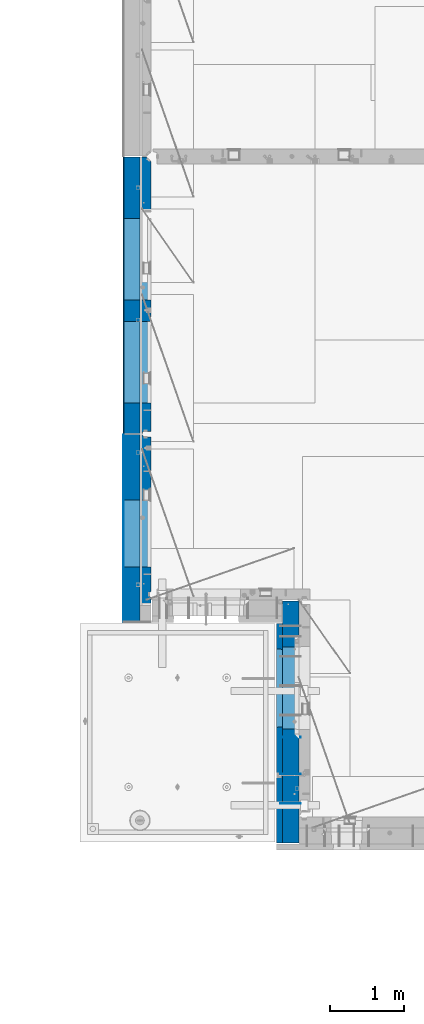
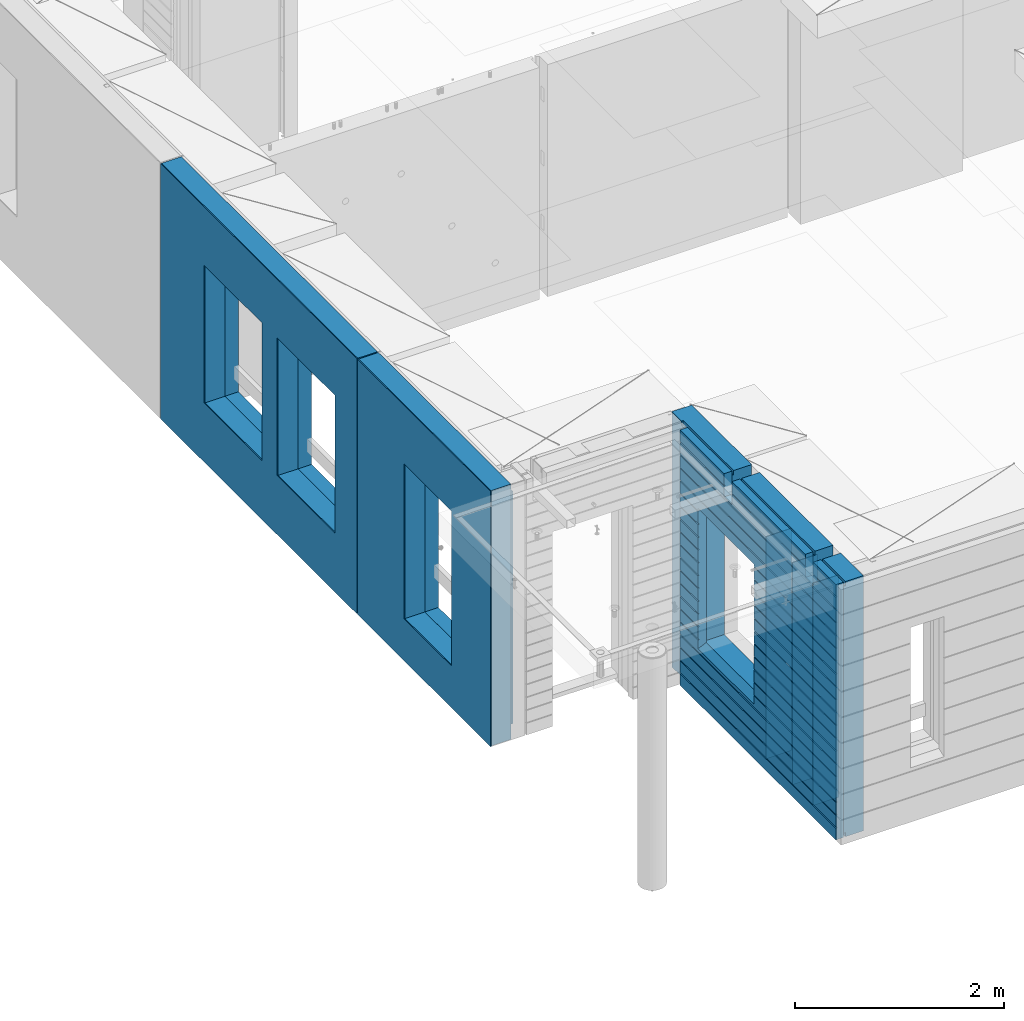
# One storey, part 219 of 341: 11 walls, 3 elements without a shape of their own.
"""IFC2X3 building model written with IfcOpenShell, lengths in millimetres."""

from ifc_helpers import new_model, si_unit, frame, origin_with_axes, place, context, subcontext, project, spatial, faceted_brep, material, type_object, element, aggregate, save


model = new_model("IFC2X3")

# Units and contexts
model_context = context("Model", 3, precision=1e-05, world=origin_with_axes())
body_context = subcontext(model_context, "Body", "Model", "MODEL_VIEW")
ifc_project = project(units=[si_unit("LENGTHUNIT", "METRE", prefix="MILLI"), si_unit("AREAUNIT", "SQUARE_METRE"), si_unit("VOLUMEUNIT", "CUBIC_METRE"), si_unit("MASSUNIT", "GRAM", prefix="KILO"), si_unit("TIMEUNIT", "SECOND"), si_unit("PLANEANGLEUNIT", "RADIAN"), si_unit("SOLIDANGLEUNIT", "STERADIAN"), si_unit("THERMODYNAMICTEMPERATUREUNIT", "DEGREE_CELSIUS"), si_unit("LUMINOUSINTENSITYUNIT", "LUMEN")], contexts=[model_context])

# Site, building, storey
site_placement = place(None, origin_with_axes())
site = spatial("IfcSite", under=ifc_project, at=site_placement, CompositionType="ELEMENT")
building_placement = place(site_placement, origin_with_axes())
building = spatial("IfcBuilding", under=site, at=building_placement, CompositionType="ELEMENT")
storey_placement = place(building_placement, origin_with_axes())
storey = spatial("IfcBuildingStorey", under=building, at=storey_placement, Name="5", CompositionType="ELEMENT", Elevation=0.0)

# Assembly, walls
assembly_1_placement = place(storey_placement, origin_with_axes())
assembly_1 = element("IfcElementAssembly", 1, at=assembly_1_placement, inside=storey, AssemblyPlace="NOTDEFINED", PredefinedType="REINFORCEMENT_UNIT")
ifc_material_1 = material(Name="Undefined")
wall_type_1 = type_object("IfcWallType", PredefinedType="NOTDEFINED")
wall_1_placement = place(assembly_1_placement, frame((10040.0, 8580.0, 95115.0), z_axis=(0.0, 0.0, 1.0), x_axis=(-1.0, 3.00000001838171e-08, 0.0)))
wall_1 = element("IfcWall", 2, at=wall_1_placement, type_object=wall_type_1, material=ifc_material_1, Name="(PD)", context=body_context, shape_type="Brep", body=[
    faceted_brep([(0.0, 5.0, -1300.0), (0.0, 5.0, 1300.0), (280.0, 5.0, 1300.0), (280.0, 5.0, -1300.0), (0.0, -5.0, 1300.0), (280.0, -5.0, 1300.0), (0.0, -5.0, -1300.0), (280.0, -5.0, -1300.0)], [[[0, 1, 2, 3]], [[1, 4, 5, 2]], [[4, 6, 7, 5]], [[6, 0, 3, 7]], [[5, 7, 3, 2]], [[6, 4, 1, 0]]]),
])
wall_2_placement = place(assembly_1_placement, frame((10040.0, 8180.0, 95115.0), z_axis=(0.0, 0.0, 1.0), x_axis=(-1.0, 3.00000001838171e-08, 0.0)))
wall_2 = element("IfcWall", 3, at=wall_2_placement, type_object=wall_type_1, material=ifc_material_1, Name="(PD)", context=body_context, shape_type="Brep", body=[
    faceted_brep([(0.0, 5.0, -1300.0), (0.0, 5.0, 1300.0), (280.0, 5.0, 1300.0), (280.0, 5.0, -1300.0), (0.0, -5.0, 1300.0), (280.0, -5.0, 1300.0), (0.0, -5.0, -1300.0), (280.0, -5.0, -1300.0)], [[[0, 1, 2, 3]], [[1, 4, 5, 2]], [[4, 6, 7, 5]], [[6, 0, 3, 7]], [[5, 7, 3, 2]], [[6, 4, 1, 0]]]),
])
wall_3_placement = place(assembly_1_placement, frame((10040.0, 9080.0, 95115.0), z_axis=(0.0, 0.0, 1.0), x_axis=(-1.0, 3.00000001838171e-08, 0.0)))
wall_3 = element("IfcWall", 4, at=wall_3_placement, type_object=wall_type_1, material=ifc_material_1, Name="(PD)", context=body_context, shape_type="Brep", body=[
    faceted_brep([(0.0, 5.0, -1300.0), (0.0, 5.0, 1300.0), (280.0, 5.0, 1300.0), (280.0, 5.0, -1300.0), (0.0, -5.0, 1300.0), (280.0, -5.0, 1300.0), (0.0, -5.0, -1300.0), (280.0, -5.0, -1300.0)], [[[0, 1, 2, 3]], [[1, 4, 5, 2]], [[4, 6, 7, 5]], [[6, 0, 3, 7]], [[5, 7, 3, 2]], [[6, 4, 1, 0]]]),
])
ifc_material_2 = material(Name="COS5gt")
wall_type_2 = type_object("IfcWallType", PredefinedType="NOTDEFINED")
wall_4_placement = place(assembly_1_placement, frame((9900.0, 8000.0, 95247.5), z_axis=(0.0, 0.0, 1.0), x_axis=(0.0, 1.0, 0.0)))
wall_4 = element("IfcWall", 5, at=wall_4_placement, type_object=wall_type_2, material=ifc_material_2, context=body_context, shape_type="Brep", body=[
    faceted_brep([(-355.0, 110.0, -1442.5), (2751.0, 110.0, -1442.5), (2751.0, 90.0, -1442.5), (-355.0, 90.0, -1442.5), (2935.0, 110.0, -1492.5), (2935.0, -110.0, -1492.5), (-355.0, -110.0, -1492.5), (-355.0, 90.0, -1492.5), (2751.0, 90.0, -1492.5), (2751.0, 110.0, -1492.5), (2935.0, -110.0, 1492.5), (2935.0, 110.0, 1492.5), (2751.0, 110.0, 1492.5), (2751.0, 90.0, 1492.5), (1785.0, 90.0, 1492.5), (1785.0, -110.0, 1492.5), (2751.0, 90.0, 1442.5), (1785.0, 90.0, 1442.5), (2751.0, 110.0, 1442.5), (1785.0, 110.0, 1442.5), (1785.0, 110.0, 1222.5), (1785.0, -110.0, 1222.5), (1635.0, 110.0, 1222.5), (1635.0, -110.0, 1222.5), (1635.0, -110.0, 1492.5), (1635.0, 90.0, 1492.5), (229.999999999998, 90.0, 1492.5), (229.999999999998, -110.0, 1492.5), (1635.0, 90.0, 1442.5), (229.999999999998, 90.0, 1442.5), (1635.0, 110.0, 1442.5), (229.999999999998, 110.0, 1442.5), (-355.0, 110.0, 1442.5), (-355.0, 90.0, 1442.5), (79.9999999999982, 90.0, 1442.5), (79.9999999999982, 110.0, 1442.5), (-355.0, 90.0, 1492.5), (-355.0, -110.0, 1492.5), (79.9999999999982, -110.0, 1492.5), (79.9999999999982, 90.0, 1492.5), (79.9999999999982, -110.0, 1222.5), (79.9999999999982, 110.0, 1222.5), (229.999999999998, -110.0, 1222.5), (229.999999999998, 110.0, 1222.5), (1189.05717134203, -110.0, -813.445945945859), (1189.05717134203, -110.0, 813.445945945859), (2310.94906323375, -110.0, 813.445945945859), (2310.94906323375, -110.0, -813.445945945859), (1195.00311728789, 109.999999996904, -807.5), (1195.00311728789, 109.999999996904, -802.5), (1195.00311728789, 109.999999996904, 807.5), (2305.00311728789, 109.999999996904, -807.5), (2275.00311728789, 109.999999996904, -807.5), (1225.00311728789, 109.999999996904, -807.5), (2305.00311728789, 109.999999996904, 807.5), (2305.00311728789, 109.999999996904, -802.5)], [[[0, 1, 2, 3]], [[4, 5, 6, 7, 8, 9]], [[10, 5, 4, 11]], [[10, 11, 12, 13, 14, 15]], [[13, 16, 17, 14]], [[12, 18, 16, 13]], [[16, 18, 19, 17]], [[15, 14, 17, 19, 20, 21]], [[21, 20, 22, 23]], [[24, 25, 26, 27]], [[25, 28, 29, 26]], [[24, 23, 22, 30, 28, 25]], [[28, 30, 31, 29]], [[32, 33, 34, 35]], [[36, 37, 38, 39]], [[33, 36, 39, 34]], [[38, 40, 41, 35, 34, 39]], [[42, 43, 41, 40]], [[27, 26, 29, 31, 43, 42]], [[40, 38, 37, 6, 5, 10, 15, 21, 23, 24, 27, 42], [44, 45, 46, 47]], [[44, 48, 49, 50, 45]], [[47, 51, 52, 53, 48, 44]], [[46, 54, 55, 51, 47]], [[45, 50, 54, 46]], [[30, 22, 20, 19, 18, 12, 11, 4, 9, 1, 0, 32, 35, 41, 43, 31], [49, 48, 53, 52, 51, 55, 54, 50]], [[8, 2, 1, 9]], [[7, 3, 2, 8]], [[6, 37, 36, 33, 32, 0, 3, 7]]]),
])

# Assembly, wall
assembly_2_placement = place(storey_placement, origin_with_axes())
assembly_2 = element("IfcElementAssembly", 6, at=assembly_2_placement, inside=storey, AssemblyPlace="NOTDEFINED", PredefinedType="REINFORCEMENT_UNIT")
ifc_material_3 = material()
wall_5_placement = place(assembly_2_placement, frame((7739.99972588711, 13210.0004309454, 95247.5), z_axis=(0.0, 0.0, 1.0), x_axis=(0.0, 1.0, 0.0)))
wall_5 = element("IfcWall", 7, at=wall_5_placement, type_object=wall_type_2, material=ifc_material_3, context=body_context, shape_type="Brep", body=[
    faceted_brep([(0.0, 110.0, 1492.5), (0.0, -110.0, 1492.5), (3759.99957708461, -110.0, 1492.5), (3759.99956102462, 110.0, 1492.5), (0.0, -110.0, -1492.5), (0.0, 110.0, -1492.5), (3759.99956102462, 110.0, -1492.5), (3759.99957708461, -110.0, -1492.5), (414.999554466332, -110.0, -802.5), (414.999554466332, -110.0, 807.5), (1524.99955446633, -110.000000000001, 807.5), (1524.99955446633, -110.000000000001, -802.5), (1814.99999876569, -110.0, -802.5), (1814.99999876569, -110.0, 807.5), (2924.99999876569, -110.0, 807.5), (2924.99999876569, -110.0, -802.5), (1814.99999876569, 110.0, -802.5), (1814.99999876569, 110.0, 807.5), (2924.99999876569, 110.0, -802.5), (2924.99999876569, 110.0, 807.5), (414.999554466332, 110.0, -802.5), (1524.99955446633, 109.999999999999, -802.5), (1524.99955446633, 109.999999999999, 807.5), (414.999554466332, 110.0, 807.5)], [[[0, 1, 2, 3]], [[4, 1, 0, 5]], [[4, 5, 6, 7]], [[2, 7, 6, 3]], [[1, 4, 7, 2], [8, 9, 10, 11], [12, 13, 14, 15]], [[12, 16, 17, 13]], [[15, 18, 16, 12]], [[14, 19, 18, 15]], [[13, 17, 19, 14]], [[5, 0, 3, 6], [20, 21, 22, 23], [16, 18, 19, 17]], [[10, 22, 21, 11]], [[9, 23, 22, 10]], [[8, 20, 23, 9]], [[11, 21, 20, 8]]]),
])

assembly_3_placement = place(storey_placement, origin_with_axes())
assembly_3 = element("IfcElementAssembly", 8, at=assembly_3_placement, inside=storey, AssemblyPlace="NOTDEFINED", PredefinedType="REINFORCEMENT_UNIT")
wall_6_placement = place(assembly_3_placement, frame((7740.00002947772, 10874.9996836349, 95247.5), z_axis=(0.0, 0.0, 1.0), x_axis=(0.0, 1.0, 0.0)))
wall_6 = element("IfcWall", 9, at=wall_6_placement, type_object=wall_type_2, material=ifc_material_3, context=body_context, shape_type="Brep", body=[
    faceted_brep([(-219.99966922487, -110.0, 1492.5), (-219.99966922487, -110.0, -1492.5), (2320.00069431996, -110.000000000001, -1492.5), (2320.00069431996, -110.000000000001, 1492.5), (520.000578694053, -110.000000000001, -1002.5), (520.000578694053, -110.000000000001, 807.5), (1430.00057869405, -110.000000000001, 807.5), (1430.00057869405, -110.000000000001, -1002.5), (-219.99966922487, 110.0, 1492.5), (2320.00069431997, 110.0, 1492.5), (-219.99966922487, 110.0, -1492.5), (2320.00069431997, 110.0, -1492.5), (520.000578694055, 110.0, -1002.5), (1430.00057869406, 110.0, -1002.5), (1430.00057869406, 110.0, 807.5), (520.000578694055, 110.0, 807.5)], [[[0, 1, 2, 3], [4, 5, 6, 7]], [[8, 0, 3, 9]], [[1, 0, 8, 10]], [[1, 10, 11, 2]], [[3, 2, 11, 9]], [[10, 8, 9, 11], [12, 13, 14, 15]], [[6, 14, 13, 7]], [[5, 15, 14, 6]], [[4, 12, 15, 5]], [[7, 13, 12, 4]]]),
])

# Wall
ifc_material_4 = material(Name="CONCRETE/C30/37")
wall_type_3 = type_object("IfcWallType", PredefinedType="NOTDEFINED")
wall_7_placement = place(assembly_1_placement, frame((9747.5, 8000.0, 95247.5), z_axis=(0.0, 0.0, 1.0), x_axis=(0.0, 1.0, 0.0)))
wall_7 = element("IfcWall", 10, at=wall_7_placement, type_object=wall_type_3, material=ifc_material_4, context=body_context, shape_type="Brep", body=[
    faceted_brep([(-355.0, 32.4999992499324, 1344.99999999921), (-355.0, 32.4999991119385, 1355.00000040044), (79.9999999999982, 32.4999991119385, 1355.00000040044), (79.9999999999982, 32.4999992499324, 1344.99999999921), (-355.0, 42.5, 1342.99999994476), (79.9999999999982, 42.5, 1342.99999994476), (2630.0, 32.4999991119385, 1355.00000040044), (2630.0, 32.4999992499324, 1344.99999999921), (1785.0, 32.4999992499324, 1344.99999999921), (1785.0, 32.4999991119385, 1355.00000040044), (2630.0, 42.5, 1356.99999988925), (1785.0, 42.5, 1356.99999988925), (2630.0, 42.5, 1492.5), (1785.0, 42.5, 1492.5), (2630.0, -42.5, 1492.5), (1785.0, -42.5, 1492.5), (-355.0, -42.5, -1492.5), (-355.0, 42.5, -1492.5), (2630.0, 42.5, -1492.5), (2630.0, -42.5, -1492.5), (-355.0, 42.5, -1357.00000005524), (2630.0, 42.5, -1357.00000005524), (-355.0, 32.4999992506928, -1355.0000000008), (2630.0, 32.4999992506928, -1355.0000000008), (-355.0, 32.4999991126915, -1344.99999959957), (2630.0, 32.4999991126915, -1344.99999959957), (-355.0, 42.5, -1343.00000011075), (2630.0, 42.5, -1343.00000011075), (-355.0, 42.5, -1207.00000005524), (2630.0, 42.5, -1207.00000005524), (-355.0, 32.4999992506928, -1205.0000000008), (2630.0, 32.4999992506928, -1205.0000000008), (-355.0, 32.4999991126915, -1194.99999959957), (2630.0, 32.4999991126915, -1194.99999959957), (-355.0, 42.5, -1193.00000011075), (2630.0, 42.5, -1193.00000011075), (-355.0, 42.5, -1057.00000005525), (2630.0, 42.5, -1057.00000005525), (-355.0, 32.4999992512294, -1055.00000000081), (2630.0, 32.4999992512294, -1055.00000000081), (-355.0, 32.4999991132281, -1044.99999959959), (2630.0, 32.4999991132281, -1044.99999959959), (-355.0, 42.5, -1043.00000011077), (2630.0, 42.5, -1043.00000011077), (-355.0, 42.5, -907.000000055225), (2630.0, 42.5, -907.000000055225), (-355.000000000001, 32.4999992517678, -905.000000000786), (2630.0, 32.4999992517678, -905.000000000786), (-355.000000000001, 32.4999991137665, -894.99999959956), (2630.0, 32.4999991137665, -894.99999959956), (-355.0, 42.5, -893.00000011074), (2630.0, 42.5, -893.00000011074), (2630.0, 42.5, -307.000000055239), (2630.0, 32.4999992538942, -305.0000000008), (2630.0, 32.4999991158911, -294.999999599575), (2630.0, 42.5, -293.000000110755), (2630.0, 42.5, -157.000000055254), (2630.0, 32.4999992544235, -155.000000000815), (2630.0, 32.4999991164223, -144.99999959959), (2630.0, 42.5, -143.000000110769), (2630.0, 42.5, -7.00000005523907), (2630.0, 32.4999992500489, -5.0000000007858), (2630.0, 32.4999991120549, 5.0000004004396), (2630.0, 42.5, 6.99999988924537), (2630.0, 42.5, 142.999999944761), (2630.0, 32.4999992500361, 144.999999999214), (2630.0, 32.4999991120421, 155.00000040044), (2630.0, 42.5, 156.999999889245), (2630.0, 42.5, 292.999999944761), (2630.0, 32.4999992500234, 294.999999999214), (2630.0, 32.4999991120294, 305.00000040044), (2630.0, 42.5, 306.999999889245), (2630.0, 42.5, 442.999999944761), (2630.0, 32.4999992500107, 444.999999999214), (2630.0, 32.4999991120167, 455.00000040044), (2630.0, 42.5, 456.999999889245), (2630.0, 42.5, 592.999999944761), (2630.0, 32.4999992499979, 594.999999999214), (2630.0, 32.4999991120039, 605.00000040044), (2630.0, 42.5, 606.999999889245), (2630.0, 42.5, 742.999999944761), (2630.0, 32.4999992499852, 744.999999999214), (2630.0, 32.4999991119912, 755.00000040044), (2630.0, 42.5, 756.999999889245), (2630.0, 42.5, 892.999999944761), (2630.0, 32.4999992499725, 894.999999999214), (2630.0, 32.4999991119785, 905.00000040044), (2630.0, 42.5, 906.999999889245), (2630.0, 42.5, 1042.99999994476), (2630.0, 32.4999992499597, 1044.99999999921), (2630.0, 32.4999991119657, 1055.00000040044), (2630.0, 42.5, 1056.99999988925), (2630.0, 42.5, 1192.99999994476), (2630.0, 32.499999249947, 1194.99999999921), (2630.0, 32.499999111953, 1205.00000040044), (2630.0, 42.5, 1206.99999988925), (2630.0, 42.5, 1342.99999994476), (2630.0, 42.5, -757.000000055225), (2630.0, 32.4999992522953, -755.000000000786), (2630.0, 32.499999114294, -744.99999959956), (2630.0, 42.5, -743.00000011074), (2630.0, 42.5, -607.000000055225), (2630.0, 32.4999992522953, -605.000000000786), (2630.0, 32.499999114294, -594.99999959956), (2630.0, 42.5, -593.00000011074), (2630.0, 42.5, -457.000000055225), (2630.0, 32.4999992522953, -455.000000000786), (2630.0, 32.499999114294, -444.99999959956), (2630.0, 42.5, -443.00000011074), (1785.0, 42.5, 1342.99999994476), (1785.0, 42.5, 1222.5), (1785.0, -42.5, 1222.5), (1635.0, 42.5, 1222.5), (1635.0, -42.5, 1222.5), (1635.0, -42.5, 1492.5), (1635.0, 42.5, 1492.5), (229.999999999998, 42.5, 1492.5), (229.999999999998, -42.5, 1492.5), (1635.0, 32.4999991119385, 1355.00000040044), (1635.0, 32.4999992499324, 1344.99999999921), (229.999999999998, 32.4999992499324, 1344.99999999921), (229.999999999998, 32.4999991119385, 1355.00000040044), (1635.0, 42.5, 1356.99999988925), (229.999999999998, 42.5, 1356.99999988925), (1635.0, 42.5, 1342.99999994476), (229.999999999998, 42.5, 1342.99999994476), (229.999999999998, -42.5, 1222.5), (229.999999999998, 42.5, 1222.5), (79.9999999999982, 42.5, 1222.5), (79.9999999999982, -42.5, 1222.5), (-355.0, 42.5, 1206.99999988925), (-355.0, 32.499999111953, 1205.00000040044), (-355.0, 32.499999249947, 1194.99999999921), (-355.0, 42.5, 1192.99999994476), (-355.0, 42.5, 1056.99999988925), (-355.0, 32.4999991119657, 1055.00000040044), (-355.0, 32.4999992499597, 1044.99999999921), (-355.0, 42.5, 1042.99999994476), (-355.0, 42.5, 906.999999889245), (-354.999999999999, 32.4999991119785, 905.00000040044), (-354.999999999999, 32.4999992499725, 894.999999999214), (-355.0, 42.5, 892.999999944761), (-355.0, 42.5, -457.000000055225), (-355.0, 42.5, -593.00000011074), (-354.999999999998, 32.499999114294, -594.99999959956), (-354.999999999998, 32.4999992522953, -605.000000000786), (-355.0, 42.5, -607.000000055225), (-355.0, 42.5, -743.00000011074), (-355.0, 32.499999114294, -744.99999959956), (-355.0, 32.4999992522953, -755.000000000786), (-355.0, 42.5, -757.000000055225), (-355.0, -42.5, 1492.5), (-355.0, 42.5, 1492.5), (-355.0, 42.5, 1356.99999988925), (-355.0, 42.5, 756.999999889245), (-354.999999999999, 32.4999991119912, 755.00000040044), (-354.999999999999, 32.4999992499852, 744.999999999214), (-355.0, 42.5, 742.999999944761), (-355.0, 42.5, 606.999999889245), (-355.0, 32.4999991120039, 605.00000040044), (-355.0, 32.4999992499979, 594.999999999214), (-355.0, 42.5, 592.999999944761), (-355.0, 42.5, 456.999999889245), (-355.0, 32.4999991120167, 455.00000040044), (-355.0, 32.4999992500107, 444.999999999214), (-355.0, 42.5, 442.999999944761), (-355.0, 42.5, 306.999999889245), (-355.0, 32.4999991120294, 305.00000040044), (-355.0, 32.4999992500234, 294.999999999214), (-355.0, 42.5, 292.999999944761), (-355.0, 42.5, 156.999999889245), (-355.0, 32.4999991120421, 155.00000040044), (-355.0, 32.4999992500361, 144.999999999214), (-355.0, 42.5, 142.999999944761), (-355.0, 42.5, 6.99999988924537), (-355.0, 32.4999991120549, 5.0000004004396), (-355.0, 32.4999992500489, -5.0000000007858), (-355.0, 42.5, -7.00000005523907), (-355.0, 42.5, -143.000000110769), (-354.999999999999, 32.4999991164223, -144.99999959959), (-354.999999999999, 32.4999992544235, -155.000000000815), (-355.0, 42.5, -157.000000055254), (-355.0, 42.5, -293.000000110755), (-355.0, 32.4999991158911, -294.999999599575), (-355.0, 32.4999992538942, -305.0000000008), (-355.0, 42.5, -307.000000055239), (-355.0, 42.5, -443.00000011074), (-355.000000000001, 32.499999114294, -444.99999959956), (-355.000000000001, 32.4999992522953, -455.000000000786), (1215.00311728789, 42.5, 756.999999889245), (1216.1795879806, 32.4999991119912, 755.00000040044), (1216.17958796436, 32.4999992499852, 744.999999999214), (1215.00311728789, 42.5, 742.999999944761), (1215.00311728789, 42.5, 606.999999889245), (1216.1795879806, 32.4999991120039, 605.00000040044), (1216.17958796436, 32.4999992499979, 594.999999999214), (1215.00311728789, 42.5, 592.999999944761), (1215.00311728789, 42.5, 456.999999889245), (1216.17958798059, 32.4999991120167, 455.00000040044), (1216.17958796436, 32.4999992500107, 444.999999999214), (1215.00311728789, 42.5, 442.999999944761), (1215.00311728789, 42.5, 306.999999889245), (1216.17958798059, 32.4999991120294, 305.00000040044), (1216.17958796436, 32.4999992500234, 294.999999999214), (1215.00311728789, 42.5, 292.999999944761), (1215.00311728789, 42.5, 156.999999889245), (1216.17958798059, 32.4999991120421, 155.00000040044), (1216.17958796436, 32.4999992500361, 144.999999999214), (1215.00311728789, 42.5, 142.999999944761), (1215.00311728789, 42.5, 6.99999988924537), (1216.17958798059, 32.4999991120549, 5.0000004004396), (1216.17958796435, 32.4999992500489, -5.0000000007858), (1215.00311728789, 42.5, -7.00000005523907), (1215.00311728789, 42.5, -143.000000110769), (1216.17958798008, 32.4999991164223, -144.99999959959), (1216.17958796384, 32.4999992544235, -155.000000000815), (1215.00311728789, 42.5, -157.000000055254), (1215.00311728789, 42.5, -293.000000110755), (1216.17958798014, 32.4999991158911, -294.999999599575), (1216.1795879639, 32.4999992538942, -305.0000000008), (1215.00311728789, 42.5, -307.000000055239), (1215.00311728789, 42.5, -443.00000011074), (1216.17958798033, 32.499999114294, -444.99999959956), (1216.17958796409, 32.4999992522953, -455.000000000786), (1215.00311728789, 42.5, -457.000000055225), (1215.00311728789, 42.5, -593.00000011074), (1216.17958798033, 32.499999114294, -594.99999959956), (1216.17958796409, 32.4999992522953, -605.000000000786), (1215.00311728789, 42.5, -607.000000055225), (1215.00311728789, 42.5, -743.00000011074), (1216.17958798033, 32.499999114294, -744.99999959956), (1216.17958796409, 32.4999992522953, -755.000000000786), (1215.00311728789, 42.5, -757.000000055225), (1215.00311728789, 42.5, -857.5), (2285.00311728789, 42.5, -857.5), (2285.00311728789, 42.5, -757.000000055225), (2283.82664661169, 32.4999992522953, -755.000000000786), (2283.82664659545, 32.499999114294, -744.99999959956), (2285.00311728789, 42.5, -743.00000011074), (2285.00311728789, 42.5, -607.000000055225), (2283.82664661169, 32.4999992522953, -605.000000000786), (2283.82664659545, 32.499999114294, -594.99999959956), (2285.00311728789, 42.5, -593.00000011074), (2285.00311728789, 42.5, -457.000000055225), (2283.82664661169, 32.4999992522953, -455.000000000786), (2283.82664659545, 32.499999114294, -444.99999959956), (2285.00311728789, 42.5, -443.00000011074), (2285.00311728789, 42.5, -307.000000055239), (2283.82664661188, 32.4999992538942, -305.0000000008), (2283.82664659564, 32.4999991158911, -294.999999599575), (2285.00311728789, 42.5, -293.000000110755), (2285.00311728789, 42.5, -157.000000055254), (2283.82664661194, 32.4999992544235, -155.000000000815), (2283.82664659571, 32.4999991164223, -144.99999959959), (2285.00311728789, 42.5, -143.000000110769), (2285.00311728789, 42.5, -7.00000005523907), (2283.82664661143, 32.4999992500489, -5.0000000007858), (2283.82664659519, 32.4999991120549, 5.0000004004396), (2285.00311728789, 42.5, 6.99999988924537), (2285.00311728789, 42.5, 142.999999944761), (2283.82664661143, 32.4999992500361, 144.999999999214), (2283.82664659519, 32.4999991120421, 155.00000040044), (2285.00311728789, 42.5, 156.999999889245), (2285.00311728789, 42.5, 292.999999944761), (2283.82664661142, 32.4999992500234, 294.999999999214), (2283.82664659519, 32.4999991120294, 305.00000040044), (2285.00311728789, 42.5, 306.999999889245), (2285.00311728789, 42.5, 442.999999944761), (2283.82664661142, 32.4999992500107, 444.999999999214), (2283.82664659519, 32.4999991120167, 455.00000040044), (2285.00311728789, 42.5, 456.999999889245), (2285.00311728789, 42.5, 592.999999944761), (2283.82664661142, 32.4999992499979, 594.999999999214), (2283.82664659519, 32.4999991120039, 605.00000040044), (2285.00311728789, 42.5, 606.999999889245), (2285.00311728789, 42.5, 742.999999944761), (2283.82664661142, 32.4999992499852, 744.999999999214), (2283.82664659518, 32.4999991119912, 755.00000040044), (2285.00311728789, 42.5, 756.999999889245), (1225.00311728789, 42.5, 782.5), (1215.00311728789, 42.5, 782.5), (2285.00311728789, 42.5, 782.5), (2275.00311728789, 42.5, 782.5), (1225.00311728789, -42.5, 787.5), (2275.00311728789, -42.5, 787.5), (1225.00311728789, -42.5, 782.5), (1225.00311728789, -42.5, -807.5), (2275.00311728789, -42.5, -807.5), (2275.00311728789, -42.5, 782.5), (79.9999999999982, -42.5, 1492.5), (79.9999999999982, 42.5, 1492.5), (79.9999999999982, 42.5, 1356.99999988925)], [[[0, 1, 2, 3]], [[4, 0, 3, 5]], [[6, 7, 8, 9]], [[10, 6, 9, 11]], [[12, 10, 11, 13]], [[14, 12, 13, 15]], [[16, 17, 18, 19]], [[18, 17, 20, 21]], [[21, 20, 22, 23]], [[23, 22, 24, 25]], [[25, 24, 26, 27]], [[28, 29, 27, 26]], [[29, 28, 30, 31]], [[31, 30, 32, 33]], [[33, 32, 34, 35]], [[35, 34, 36, 37]], [[37, 36, 38, 39]], [[39, 38, 40, 41]], [[41, 40, 42, 43]], [[43, 42, 44, 45]], [[45, 44, 46, 47]], [[47, 46, 48, 49]], [[49, 48, 50, 51]], [[52, 53, 54, 55, 56, 57, 58, 59, 60, 61, 62, 63, 64, 65, 66, 67, 68, 69, 70, 71, 72, 73, 74, 75, 76, 77, 78, 79, 80, 81, 82, 83, 84, 85, 86, 87, 88, 89, 90, 91, 92, 93, 94, 95, 96, 7, 6, 10, 12, 14, 19, 18, 21, 23, 25, 27, 29, 31, 33, 35, 37, 39, 41, 43, 45, 47, 49, 51, 97, 98, 99, 100, 101, 102, 103, 104, 105, 106, 107, 108]], [[7, 96, 109, 8]], [[15, 13, 11, 9, 8, 109, 110, 111]], [[111, 110, 112, 113]], [[114, 115, 116, 117]], [[118, 119, 120, 121]], [[122, 118, 121, 123]], [[115, 122, 123, 116]], [[114, 113, 112, 124, 119, 118, 122, 115]], [[119, 124, 125, 120]], [[126, 127, 128, 129]], [[117, 116, 123, 121, 120, 125, 127, 126]], [[124, 112, 110, 109, 96, 95, 130, 4, 5, 128, 127, 125]], [[94, 131, 130, 95]], [[93, 132, 131, 94]], [[92, 133, 132, 93]], [[91, 134, 133, 92]], [[90, 135, 134, 91]], [[89, 136, 135, 90]], [[88, 137, 136, 89]], [[87, 138, 137, 88]], [[86, 139, 138, 87]], [[85, 140, 139, 86]], [[84, 141, 140, 85]], [[142, 143, 144, 145, 146, 147, 148, 149, 150, 50, 48, 46, 44, 42, 40, 38, 36, 34, 32, 30, 28, 26, 24, 22, 20, 17, 16, 151, 152, 153, 1, 0, 4, 130, 131, 132, 133, 134, 135, 136, 137, 138, 139, 140, 141, 154, 155, 156, 157, 158, 159, 160, 161, 162, 163, 164, 165, 166, 167, 168, 169, 170, 171, 172, 173, 174, 175, 176, 177, 178, 179, 180, 181, 182, 183, 184, 185, 186, 187, 188]], [[155, 154, 189, 190]], [[156, 155, 190, 191]], [[157, 156, 191, 192]], [[158, 157, 192, 193]], [[159, 158, 193, 194]], [[160, 159, 194, 195]], [[161, 160, 195, 196]], [[162, 161, 196, 197]], [[163, 162, 197, 198]], [[164, 163, 198, 199]], [[165, 164, 199, 200]], [[166, 165, 200, 201]], [[167, 166, 201, 202]], [[168, 167, 202, 203]], [[169, 168, 203, 204]], [[170, 169, 204, 205]], [[171, 170, 205, 206]], [[172, 171, 206, 207]], [[173, 172, 207, 208]], [[174, 173, 208, 209]], [[175, 174, 209, 210]], [[176, 175, 210, 211]], [[177, 176, 211, 212]], [[178, 177, 212, 213]], [[179, 178, 213, 214]], [[180, 179, 214, 215]], [[181, 180, 215, 216]], [[182, 181, 216, 217]], [[183, 182, 217, 218]], [[184, 183, 218, 219]], [[185, 184, 219, 220]], [[186, 185, 220, 221]], [[187, 186, 221, 222]], [[188, 187, 222, 223]], [[142, 188, 223, 224]], [[143, 142, 224, 225]], [[144, 143, 225, 226]], [[145, 144, 226, 227]], [[146, 145, 227, 228]], [[147, 146, 228, 229]], [[148, 147, 229, 230]], [[149, 148, 230, 231]], [[150, 149, 231, 232]], [[97, 51, 50, 150, 232, 233, 234, 235]], [[98, 97, 235, 236]], [[99, 98, 236, 237]], [[100, 99, 237, 238]], [[101, 100, 238, 239]], [[102, 101, 239, 240]], [[103, 102, 240, 241]], [[104, 103, 241, 242]], [[105, 104, 242, 243]], [[106, 105, 243, 244]], [[107, 106, 244, 245]], [[108, 107, 245, 246]], [[52, 108, 246, 247]], [[53, 52, 247, 248]], [[54, 53, 248, 249]], [[55, 54, 249, 250]], [[56, 55, 250, 251]], [[57, 56, 251, 252]], [[58, 57, 252, 253]], [[59, 58, 253, 254]], [[60, 59, 254, 255]], [[61, 60, 255, 256]], [[62, 61, 256, 257]], [[63, 62, 257, 258]], [[64, 63, 258, 259]], [[65, 64, 259, 260]], [[66, 65, 260, 261]], [[67, 66, 261, 262]], [[68, 67, 262, 263]], [[69, 68, 263, 264]], [[70, 69, 264, 265]], [[71, 70, 265, 266]], [[72, 71, 266, 267]], [[73, 72, 267, 268]], [[74, 73, 268, 269]], [[75, 74, 269, 270]], [[76, 75, 270, 271]], [[77, 76, 271, 272]], [[78, 77, 272, 273]], [[79, 78, 273, 274]], [[80, 79, 274, 275]], [[81, 80, 275, 276]], [[82, 81, 276, 277]], [[83, 82, 277, 278]], [[279, 280, 189, 154, 141, 84, 83, 278, 281, 282]], [[283, 280, 279, 282, 281, 284]], [[285, 286, 233, 232, 231, 230, 229, 228, 227, 226, 225, 224, 223, 222, 221, 220, 219, 218, 217, 216, 215, 214, 213, 212, 211, 210, 209, 208, 207, 206, 205, 204, 203, 202, 201, 200, 199, 198, 197, 196, 195, 194, 193, 192, 191, 190, 189, 280, 283]], [[287, 234, 233, 286]], [[288, 284, 281, 278, 277, 276, 275, 274, 273, 272, 271, 270, 269, 268, 267, 266, 265, 264, 263, 262, 261, 260, 259, 258, 257, 256, 255, 254, 253, 252, 251, 250, 249, 248, 247, 246, 245, 244, 243, 242, 241, 240, 239, 238, 237, 236, 235, 234, 287]], [[129, 289, 151, 16, 19, 14, 15, 111, 113, 114, 117, 126], [287, 286, 285, 283, 284, 288]], [[152, 151, 289, 290]], [[153, 152, 290, 291]], [[289, 129, 128, 5, 3, 2, 291, 290]], [[1, 153, 291, 2]]]),
])

aggregate(assembly_1, [wall_1, wall_2, wall_3, wall_4, wall_7])

ifc_material_5 = material(Name="CONCRETE/C25/30")
wall_type_4 = type_object("IfcWallType", PredefinedType="NOTDEFINED")
wall_8_placement = place(assembly_2_placement, frame((7924.9997258893, 13210.0004174404, 95112.5), z_axis=(0.0, 0.0, 1.0), x_axis=(0.0, 1.0, 0.0)))
wall_8 = element("IfcWall", 11, at=wall_8_placement, type_object=wall_type_4, material=ifc_material_5, context=body_context, shape_type="Brep", body=[
    faceted_brep([(1524.99955451006, -75.0000000617138, -667.5), (1524.99955451006, 75.0, -667.5), (414.999554510065, 75.0, -667.5), (414.999554510063, -75.000000114278, -667.5), (414.999554510065, 75.0, 942.5), (414.999554510063, -75.0000002207053, 942.5), (1524.99955451006, 75.0, 942.5), (1524.99955451006, -75.000000168141, 942.5), (0.0, 45.0, 1357.5), (0.0, 45.0, -1357.5), (29.9999989126591, 32.0000004547946, -1357.5), (29.9999989126591, 32.0000004547946, 1357.5), (0.0, 75.0, 1357.5), (0.0, 75.0, -1357.5), (3759.99957708464, 74.9999999999991, -1357.5), (3759.99957708464, 74.9999999999991, 1357.5), (3759.99958365464, -14.9999989005837, 1357.5), (3759.99958365464, -14.9999989005837, -1357.5), (30.0000016637459, -75.0, -1357.5), (3699.99959131522, -75.0000000000018, -1357.5), (30.0000016637459, -75.0, 1357.5), (3699.99959130954, -75.0000000056843, 1357.5), (1814.99999880942, -75.0000000486807, -667.5), (1814.99999880942, -75.0000001534236, 942.5), (2924.99999880942, -75.0000001008593, 942.5), (2924.99999880942, -74.9999999961165, -667.5), (1814.99999880942, 74.9999999999991, -667.5), (1814.99999880942, 74.9999999999991, 942.5), (2924.99999880942, 74.9999999999991, -667.5), (2924.99999880942, 74.9999999999991, 942.5)], [[[0, 1, 2, 3]], [[3, 2, 4, 5]], [[5, 4, 6, 7]], [[7, 6, 1, 0]], [[8, 9, 10, 11]], [[12, 13, 9, 8]], [[14, 15, 16, 17]], [[18, 10, 9, 13, 14, 17, 19]], [[11, 10, 18, 20]], [[15, 12, 8, 11, 20, 21, 16]], [[17, 16, 21, 19]], [[20, 18, 19, 21], [3, 5, 7, 0], [22, 23, 24, 25]], [[22, 26, 27, 23]], [[25, 28, 26, 22]], [[24, 29, 28, 25]], [[23, 27, 29, 24]], [[13, 12, 15, 14], [2, 1, 6, 4], [26, 28, 29, 27]]]),
])

wall_9_placement = place(assembly_3_placement, frame((7924.99999901751, 11107.4999902026, 95112.5), z_axis=(0.0, 0.0, 1.0), x_axis=(0.0, 1.0, 0.0)))
wall_9 = element("IfcWall", 12, at=wall_9_placement, type_object=wall_type_4, material=ifc_material_5, context=body_context, shape_type="Brep", body=[
    faceted_brep([(1197.50029630646, -74.9999998966041, -867.5), (1197.50029630646, 74.9999999999982, -867.5), (287.500296306462, 74.9999999999991, -867.5), (287.500296306462, -74.9999993964047, -867.5), (287.500296306462, 74.9999999999991, 942.5), (287.500296306462, -74.9999986286903, 942.5), (1197.50029630646, 74.9999999999982, 942.5), (1197.50029630646, -74.9999991288896, 942.5), (2087.5004119875, 44.9999999972642, 1357.5), (2087.5004119875, 74.9999999999991, 1357.5), (-232.500282332605, 74.9999999999991, 1357.5), (-232.500282332603, -75.0000000000009, 1357.5), (-122.50000002761, -75.0000000000009, 1357.5), (-109.499996997054, -54.9999860283524, 1357.5), (-55.4999970925001, -54.9999931295279, 1357.5), (-42.4999972430833, -74.9999976941244, 1357.5), (2057.50041198727, -75.0000000027349, 1357.5), (2057.50041198727, 24.9999999972651, 1357.5), (-232.500282332603, -75.0000000000009, -1357.5), (-232.500282332605, 74.9999999999991, -1357.5), (-122.50000002761, -75.0000000000009, -1357.5), (-109.499996997054, -54.9999860283524, -1357.5), (-55.4999970925001, -54.9999931295279, -1357.5), (-42.4999972430851, -75.0000000000009, -1357.5), (2057.50041198727, -75.0000000000009, -1357.5), (2057.50041198727, 24.9999999972651, -1357.5), (2087.5004119875, 74.9999999999991, -1357.5), (2087.5004119875, 44.9999999972642, -1357.5)], [[[0, 1, 2, 3]], [[3, 2, 4, 5]], [[5, 4, 6, 7]], [[7, 6, 1, 0]], [[8, 9, 10, 11, 12, 13, 14, 15, 16, 17]], [[18, 11, 10, 19]], [[11, 18, 20, 12]], [[12, 20, 21, 13]], [[13, 21, 22, 14]], [[15, 14, 22, 23]], [[15, 23, 24, 16], [3, 5, 7, 0]], [[16, 24, 25, 17]], [[23, 22, 21, 20, 18, 19, 26, 27, 25, 24]], [[17, 25, 27, 8]], [[26, 9, 8, 27]], [[19, 10, 9, 26], [2, 1, 6, 4]]]),
])

wall_type_5 = type_object("IfcWallType", PredefinedType="NOTDEFINED")
wall_10_placement = place(assembly_2_placement, frame((7624.9997258871, 13210.0004393404, 95247.5), z_axis=(0.0, 0.0, 1.0), x_axis=(0.0, 1.0, 0.0)))
wall_10 = element("IfcWall", 13, at=wall_10_placement, type_object=wall_type_5, material=ifc_material_4, context=body_context, shape_type="Brep", body=[
    faceted_brep([(0.0, 5.0, 1492.5), (0.0, -5.0, 1492.5), (3759.99956102465, -5.00000000000091, 1492.5), (3759.99956029465, 4.99999999999909, 1492.5), (0.0, -5.0, -1492.5), (0.0, 5.0, -1492.5), (3759.99956029465, 4.99999999999909, -1492.5), (3759.99956102465, -5.00000000000091, -1492.5), (414.999554402322, -5.00000000000091, -802.5), (414.999554402322, -5.00000000000091, 807.5), (1524.99955440232, -5.00000000000182, 807.5), (1524.99955440232, -5.00000000000182, -802.5), (1814.99999870163, -5.00000000000091, -802.5), (1814.99999870163, -5.00000000000091, 807.5), (2924.99999870163, -5.00000000000091, 807.5), (2924.99999870163, -5.00000000000091, -802.5), (1814.99999870163, 4.99999999999909, -802.5), (1814.99999870163, 4.99999999999909, 807.5), (2924.99999870163, 4.99999999999909, -802.5), (2924.99999870163, 4.99999999999909, 807.5), (414.999554402326, 4.99999999999818, -802.5), (1524.99955440232, 4.99999999999818, -802.5), (1524.99955440232, 4.99999999999818, 807.5), (414.999554402326, 4.99999999999818, 807.5)], [[[0, 1, 2, 3]], [[4, 1, 0, 5]], [[4, 5, 6, 7]], [[2, 7, 6, 3]], [[1, 4, 7, 2], [8, 9, 10, 11], [12, 13, 14, 15]], [[12, 16, 17, 13]], [[15, 18, 16, 12]], [[14, 19, 18, 15]], [[13, 17, 19, 14]], [[5, 0, 3, 6], [20, 21, 22, 23], [16, 18, 19, 17]], [[10, 22, 21, 11]], [[9, 23, 22, 10]], [[8, 20, 23, 9]], [[11, 21, 20, 8]]]),
])

aggregate(assembly_2, [wall_10, wall_5, wall_8])

wall_11_placement = place(assembly_3_placement, frame((7625.00002947765, 10874.99966857, 95247.5), z_axis=(0.0, 0.0, 1.0), x_axis=(0.0, 1.0, 0.0)))
wall_11 = element("IfcWall", 14, at=wall_11_placement, type_object=wall_type_5, material=ifc_material_4, context=body_context, shape_type="Brep", body=[
    faceted_brep([(-230.0, -5.0, 1492.5), (-230.0, -5.0, -1492.5), (2320.00069431993, -5.0, -1492.5), (2320.00069431993, -5.0, 1492.5), (520.000578774374, -5.0, -1002.5), (520.000578774374, -5.0, 807.5), (1430.00057877438, -5.0, 807.5), (1430.00057877438, -5.0, -1002.5), (-230.0, 5.0, 1492.5), (2320.00069431993, 5.0, 1492.5), (-230.0, 5.0, -1492.5), (2320.00069431993, 5.0, -1492.5), (520.000578774374, 5.0, -1002.5), (1430.00057877438, 5.0, -1002.5), (1430.00057877438, 5.0, 807.5), (520.000578774374, 5.0, 807.5)], [[[0, 1, 2, 3], [4, 5, 6, 7]], [[8, 0, 3, 9]], [[1, 0, 8, 10]], [[1, 10, 11, 2]], [[3, 2, 11, 9]], [[10, 8, 9, 11], [12, 13, 14, 15]], [[6, 14, 13, 7]], [[5, 15, 14, 6]], [[4, 12, 15, 5]], [[7, 13, 12, 4]]]),
])

aggregate(assembly_3, [wall_11, wall_6, wall_9])

save(model, "model.ifc")
